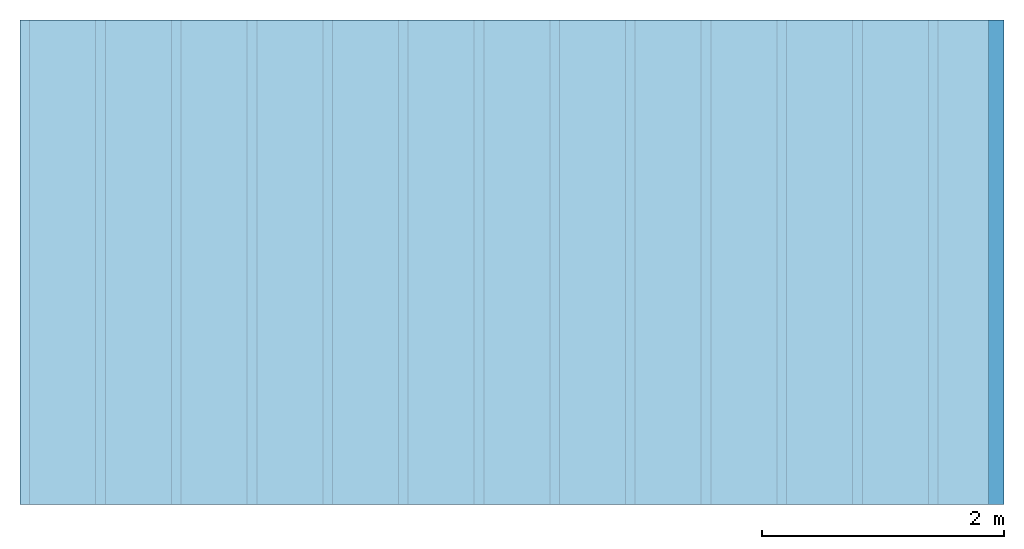
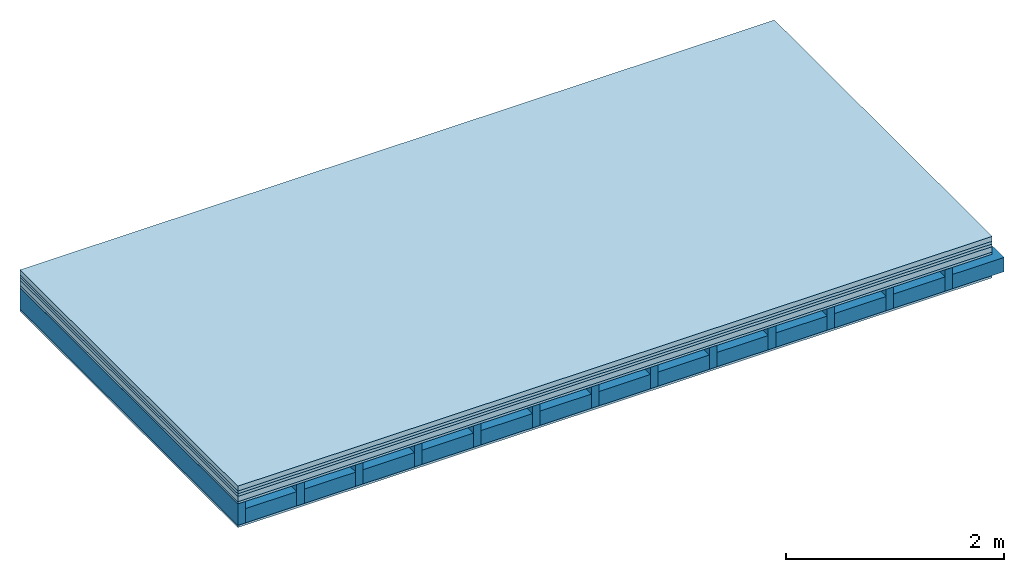
# One storey: 6 plates, 2 members, 1 element without a shape of its own.
"""IFC4 building model written with IfcOpenShell, lengths in metres."""

from ifc_helpers import new_model, si_unit, derived_unit, direction, frame, frame_2d, origin, origin_with_axes, place, context, project, spatial, rectangle, extrude, material, layer, layer_set, type_object, element, aggregate, save


model = new_model("IFC4")

# Units and contexts
plan_context = context("Plan", 3, precision=1e-05, world=origin(), true_north=direction((0.0, 1.0)))
model_context = context("Model", 3, precision=1e-05, world=origin(), true_north=direction((0.0, 1.0)))
ifc_project = project(units=[si_unit("LENGTHUNIT", "METRE"), derived_unit("SOUNDPRESSUREUNIT", [(si_unit("PRESSUREUNIT", "PASCAL", prefix="MICRO"), 0)]), si_unit("ENERGYUNIT", "JOULE", prefix="MEGA"), si_unit("MASSUNIT", "GRAM", prefix="KILO"), derived_unit("THERMALTRANSMITTANCEUNIT", [(si_unit("POWERUNIT", "WATT"), 1), (si_unit("AREAUNIT", "SQUARE_METRE"), -1), (si_unit("THERMODYNAMICTEMPERATUREUNIT", "KELVIN"), -1)]), derived_unit("AREADENSITYUNIT", [(si_unit("MASSUNIT", "GRAM", prefix="KILO"), 1), (si_unit("AREAUNIT", "SQUARE_METRE"), -1)]), derived_unit("USERDEFINED", [(si_unit("ENERGYUNIT", "JOULE", prefix="MEGA"), 1), (si_unit("AREAUNIT", "SQUARE_METRE"), -1)])], contexts=[plan_context, model_context])

# Site, building, storey
site = spatial("IfcSite", under=ifc_project)
building_placement = place(None, origin())
building = spatial("IfcBuilding", under=site, at=building_placement)
storey_placement = place(building_placement, origin())
storey = spatial("IfcBuildingStorey", under=building, at=storey_placement)

# Slab, members, plates
ifc_material_1 = material(Category="04.005")
ifc_layer_1 = layer(ifc_material_1, 0.055, Name="On-material")
ifc_material_2 = material()
ifc_layer_2 = layer(ifc_material_2, 0.03, Name="Impact sound insulation")
ifc_material_3 = material()
ifc_layer_3 = layer(ifc_material_3, 0.03, Name="Additional insulation")
ifc_material_4 = material(Name="Cement panels, glued on sub-floor", Category="02.007")
ifc_layer_4 = layer(ifc_material_4, 0.06, Name="on Supporting structure")
ifc_material_5 = material(Category="07.001")
ifc_layer_5 = layer(ifc_material_5, 0.025, Name="Sub-floor")
ifc_material_6 = material(Name="Rigid, of the art")
ifc_layer_6 = layer(ifc_material_6, 0.0, Name="Bond")
ifc_layer_7 = layer(None, 0.24, Name="Supporting structure")
ifc_layer_8 = layer(ifc_material_6, 0.0, Name="Bond")
ifc_layer_9 = layer(ifc_material_5, 0.025, Name="Lower layer 1")
ifc_layer_set = layer_set([ifc_layer_1, ifc_layer_2, ifc_layer_3, ifc_layer_4, ifc_layer_5, ifc_layer_6, ifc_layer_7, ifc_layer_8, ifc_layer_9])
slab_type = type_object("IfcSlabType", Name="A0427", PredefinedType="NOTDEFINED", material=ifc_layer_set)
slab_placement = place(None, frame((0.0, 0.0, 0.0), z_axis=(0.0, 0.0, -1.0), x_axis=(1.0, 0.0, 0.0)))
slab = element("IfcSlab", 1, at=slab_placement, inside=storey, type_object=slab_type, material=ifc_layer_set, Name="Slab #1")
ifc_material_7 = material()
member_1_placement = place(slab_placement, origin())
member_1 = element("IfcMember", 2, at=member_1_placement, material=ifc_material_7, Name="Supporting structure", context=plan_context, shape_type="SweptSolid", body=[
    extrude(rectangle(XDim=0.08, YDim=0.24, at=frame_2d((0.04, 0.12), x_axis=(1.0, 0.0))), frame((0.0, 4.0, 0.2), z_axis=(0.0, -1.0, 0.0), x_axis=(1.0, 0.0, 0.0)), (0.0, 0.0, 1.0), 4.0),
    extrude(rectangle(XDim=0.08, YDim=0.24, at=frame_2d((0.04, 0.12), x_axis=(1.0, 0.0))), frame((0.625, 4.0, 0.2), z_axis=(0.0, -1.0, 0.0), x_axis=(1.0, 0.0, 0.0)), (0.0, 0.0, 1.0), 4.0),
    extrude(rectangle(XDim=0.08, YDim=0.24, at=frame_2d((0.04, 0.12), x_axis=(1.0, 0.0))), frame((1.25, 4.0, 0.2), z_axis=(0.0, -1.0, 0.0), x_axis=(1.0, 0.0, 0.0)), (0.0, 0.0, 1.0), 4.0),
    extrude(rectangle(XDim=0.08, YDim=0.24, at=frame_2d((0.04, 0.12), x_axis=(1.0, 0.0))), frame((1.875, 4.0, 0.2), z_axis=(0.0, -1.0, 0.0), x_axis=(1.0, 0.0, 0.0)), (0.0, 0.0, 1.0), 4.0),
    extrude(rectangle(XDim=0.08, YDim=0.24, at=frame_2d((0.04, 0.12), x_axis=(1.0, 0.0))), frame((2.5, 4.0, 0.2), z_axis=(0.0, -1.0, 0.0), x_axis=(1.0, 0.0, 0.0)), (0.0, 0.0, 1.0), 4.0),
    extrude(rectangle(XDim=0.08, YDim=0.24, at=frame_2d((0.04, 0.12), x_axis=(1.0, 0.0))), frame((3.125, 4.0, 0.2), z_axis=(0.0, -1.0, 0.0), x_axis=(1.0, 0.0, 0.0)), (0.0, 0.0, 1.0), 4.0),
    extrude(rectangle(XDim=0.08, YDim=0.24, at=frame_2d((0.04, 0.12), x_axis=(1.0, 0.0))), frame((3.75, 4.0, 0.2), z_axis=(0.0, -1.0, 0.0), x_axis=(1.0, 0.0, 0.0)), (0.0, 0.0, 1.0), 4.0),
    extrude(rectangle(XDim=0.08, YDim=0.24, at=frame_2d((0.04, 0.12), x_axis=(1.0, 0.0))), frame((4.375, 4.0, 0.2), z_axis=(0.0, -1.0, 0.0), x_axis=(1.0, 0.0, 0.0)), (0.0, 0.0, 1.0), 4.0),
    extrude(rectangle(XDim=0.08, YDim=0.24, at=frame_2d((0.04, 0.12), x_axis=(1.0, 0.0))), frame((5.0, 4.0, 0.2), z_axis=(0.0, -1.0, 0.0), x_axis=(1.0, 0.0, 0.0)), (0.0, 0.0, 1.0), 4.0),
    extrude(rectangle(XDim=0.08, YDim=0.24, at=frame_2d((0.04, 0.12), x_axis=(1.0, 0.0))), frame((5.625, 4.0, 0.2), z_axis=(0.0, -1.0, 0.0), x_axis=(1.0, 0.0, 0.0)), (0.0, 0.0, 1.0), 4.0),
    extrude(rectangle(XDim=0.08, YDim=0.24, at=frame_2d((0.04, 0.12), x_axis=(1.0, 0.0))), frame((6.25, 4.0, 0.2), z_axis=(0.0, -1.0, 0.0), x_axis=(1.0, 0.0, 0.0)), (0.0, 0.0, 1.0), 4.0),
    extrude(rectangle(XDim=0.08, YDim=0.24, at=frame_2d((0.04, 0.12), x_axis=(1.0, 0.0))), frame((6.875, 4.0, 0.2), z_axis=(0.0, -1.0, 0.0), x_axis=(1.0, 0.0, 0.0)), (0.0, 0.0, 1.0), 4.0),
    extrude(rectangle(XDim=0.08, YDim=0.24, at=frame_2d((0.04, 0.12), x_axis=(1.0, 0.0))), frame((7.5, 4.0, 0.2), z_axis=(0.0, -1.0, 0.0), x_axis=(1.0, 0.0, 0.0)), (0.0, 0.0, 1.0), 4.0),
])
ifc_material_8 = material()
member_2_placement = place(slab_placement, origin())
member_2 = element("IfcMember", 3, at=member_2_placement, material=ifc_material_8, Name="Cavity", context=plan_context, shape_type="SweptSolid", body=[
    extrude(rectangle(XDim=0.545, YDim=0.16, at=frame_2d((0.2725, 0.08), x_axis=(1.0, 0.0))), frame((0.08, 4.0, 0.28), z_axis=(0.0, -1.0, 0.0), x_axis=(1.0, 0.0, 0.0)), (0.0, 0.0, 1.0), 4.0),
    extrude(rectangle(XDim=0.545, YDim=0.16, at=frame_2d((0.2725, 0.08), x_axis=(1.0, 0.0))), frame((0.705, 4.0, 0.28), z_axis=(0.0, -1.0, 0.0), x_axis=(1.0, 0.0, 0.0)), (0.0, 0.0, 1.0), 4.0),
    extrude(rectangle(XDim=0.545, YDim=0.16, at=frame_2d((0.2725, 0.08), x_axis=(1.0, 0.0))), frame((1.33, 4.0, 0.28), z_axis=(0.0, -1.0, 0.0), x_axis=(1.0, 0.0, 0.0)), (0.0, 0.0, 1.0), 4.0),
    extrude(rectangle(XDim=0.545, YDim=0.16, at=frame_2d((0.2725, 0.08), x_axis=(1.0, 0.0))), frame((1.955, 4.0, 0.28), z_axis=(0.0, -1.0, 0.0), x_axis=(1.0, 0.0, 0.0)), (0.0, 0.0, 1.0), 4.0),
    extrude(rectangle(XDim=0.545, YDim=0.16, at=frame_2d((0.2725, 0.08), x_axis=(1.0, 0.0))), frame((2.58, 4.0, 0.28), z_axis=(0.0, -1.0, 0.0), x_axis=(1.0, 0.0, 0.0)), (0.0, 0.0, 1.0), 4.0),
    extrude(rectangle(XDim=0.545, YDim=0.16, at=frame_2d((0.2725, 0.08), x_axis=(1.0, 0.0))), frame((3.205, 4.0, 0.28), z_axis=(0.0, -1.0, 0.0), x_axis=(1.0, 0.0, 0.0)), (0.0, 0.0, 1.0), 4.0),
    extrude(rectangle(XDim=0.545, YDim=0.16, at=frame_2d((0.2725, 0.08), x_axis=(1.0, 0.0))), frame((3.83, 4.0, 0.28), z_axis=(0.0, -1.0, 0.0), x_axis=(1.0, 0.0, 0.0)), (0.0, 0.0, 1.0), 4.0),
    extrude(rectangle(XDim=0.545, YDim=0.16, at=frame_2d((0.2725, 0.08), x_axis=(1.0, 0.0))), frame((4.455, 4.0, 0.28), z_axis=(0.0, -1.0, 0.0), x_axis=(1.0, 0.0, 0.0)), (0.0, 0.0, 1.0), 4.0),
    extrude(rectangle(XDim=0.545, YDim=0.16, at=frame_2d((0.2725, 0.08), x_axis=(1.0, 0.0))), frame((5.08, 4.0, 0.28), z_axis=(0.0, -1.0, 0.0), x_axis=(1.0, 0.0, 0.0)), (0.0, 0.0, 1.0), 4.0),
    extrude(rectangle(XDim=0.545, YDim=0.16, at=frame_2d((0.2725, 0.08), x_axis=(1.0, 0.0))), frame((5.705, 4.0, 0.28), z_axis=(0.0, -1.0, 0.0), x_axis=(1.0, 0.0, 0.0)), (0.0, 0.0, 1.0), 4.0),
    extrude(rectangle(XDim=0.545, YDim=0.16, at=frame_2d((0.2725, 0.08), x_axis=(1.0, 0.0))), frame((6.33, 4.0, 0.28), z_axis=(0.0, -1.0, 0.0), x_axis=(1.0, 0.0, 0.0)), (0.0, 0.0, 1.0), 4.0),
    extrude(rectangle(XDim=0.545, YDim=0.16, at=frame_2d((0.2725, 0.08), x_axis=(1.0, 0.0))), frame((6.955, 4.0, 0.28), z_axis=(0.0, -1.0, 0.0), x_axis=(1.0, 0.0, 0.0)), (0.0, 0.0, 1.0), 4.0),
    extrude(rectangle(XDim=0.545, YDim=0.16, at=frame_2d((0.2725, 0.08), x_axis=(1.0, 0.0))), frame((7.58, 4.0, 0.28), z_axis=(0.0, -1.0, 0.0), x_axis=(1.0, 0.0, 0.0)), (0.0, 0.0, 1.0), 4.0),
])
plate_1_placement = place(slab_placement, origin())
plate_1 = element("IfcPlate", 4, at=plate_1_placement, material=ifc_material_1, Name="On-material", context=plan_context, shape_type="SweptSolid", body=[
    extrude(rectangle(XDim=8.0, YDim=4.0, at=frame_2d((4.0, 2.0), x_axis=(1.0, 0.0))), origin_with_axes(), (0.0, 0.0, 1.0), 0.055),
])
plate_2_placement = place(slab_placement, origin())
plate_2 = element("IfcPlate", 5, at=plate_2_placement, material=ifc_material_2, Name="Impact sound insulation", context=plan_context, shape_type="SweptSolid", body=[
    extrude(rectangle(XDim=8.0, YDim=4.0, at=frame_2d((4.0, 2.0), x_axis=(1.0, 0.0))), frame((0.0, 0.0, 0.055), z_axis=(0.0, 0.0, 1.0), x_axis=(1.0, 0.0, 0.0)), (0.0, 0.0, 1.0), 0.03),
])
plate_3_placement = place(slab_placement, origin())
plate_3 = element("IfcPlate", 6, at=plate_3_placement, material=ifc_material_3, Name="Additional insulation", context=plan_context, shape_type="SweptSolid", body=[
    extrude(rectangle(XDim=8.0, YDim=4.0, at=frame_2d((4.0, 2.0), x_axis=(1.0, 0.0))), frame((0.0, 0.0, 0.085), z_axis=(0.0, 0.0, 1.0), x_axis=(1.0, 0.0, 0.0)), (0.0, 0.0, 1.0), 0.03),
])
plate_4_placement = place(slab_placement, origin())
plate_4 = element("IfcPlate", 7, at=plate_4_placement, material=ifc_material_4, Name="on Supporting structure", context=plan_context, shape_type="SweptSolid", body=[
    extrude(rectangle(XDim=8.0, YDim=4.0, at=frame_2d((4.0, 2.0), x_axis=(1.0, 0.0))), frame((0.0, 0.0, 0.115), z_axis=(0.0, 0.0, 1.0), x_axis=(1.0, 0.0, 0.0)), (0.0, 0.0, 1.0), 0.06),
])
plate_5_placement = place(slab_placement, origin())
plate_5 = element("IfcPlate", 8, at=plate_5_placement, material=ifc_material_5, Name="Sub-floor", context=plan_context, shape_type="SweptSolid", body=[
    extrude(rectangle(XDim=8.0, YDim=4.0, at=frame_2d((4.0, 2.0), x_axis=(1.0, 0.0))), frame((0.0, 0.0, 0.175), z_axis=(0.0, 0.0, 1.0), x_axis=(1.0, 0.0, 0.0)), (0.0, 0.0, 1.0), 0.025),
])
plate_6_placement = place(slab_placement, origin())
plate_6 = element("IfcPlate", 9, at=plate_6_placement, material=ifc_material_5, Name="Lower layer 1", context=plan_context, shape_type="SweptSolid", body=[
    extrude(rectangle(XDim=8.0, YDim=4.0, at=frame_2d((4.0, 2.0), x_axis=(1.0, 0.0))), frame((0.0, 0.0, 0.44), z_axis=(0.0, 0.0, 1.0), x_axis=(1.0, 0.0, 0.0)), (0.0, 0.0, 1.0), 0.025),
])
aggregate(slab, [plate_1, plate_2, plate_3, plate_4, plate_5, member_1, member_2, plate_6])

save(model, "model.ifc")
